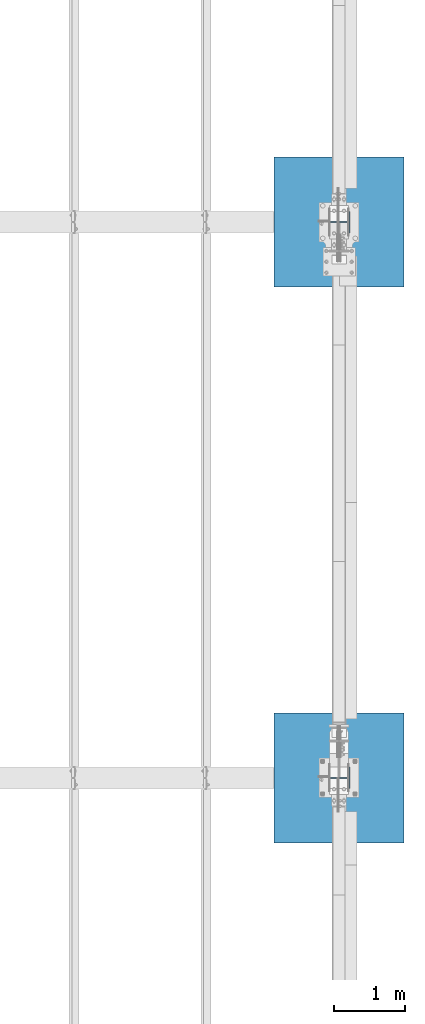
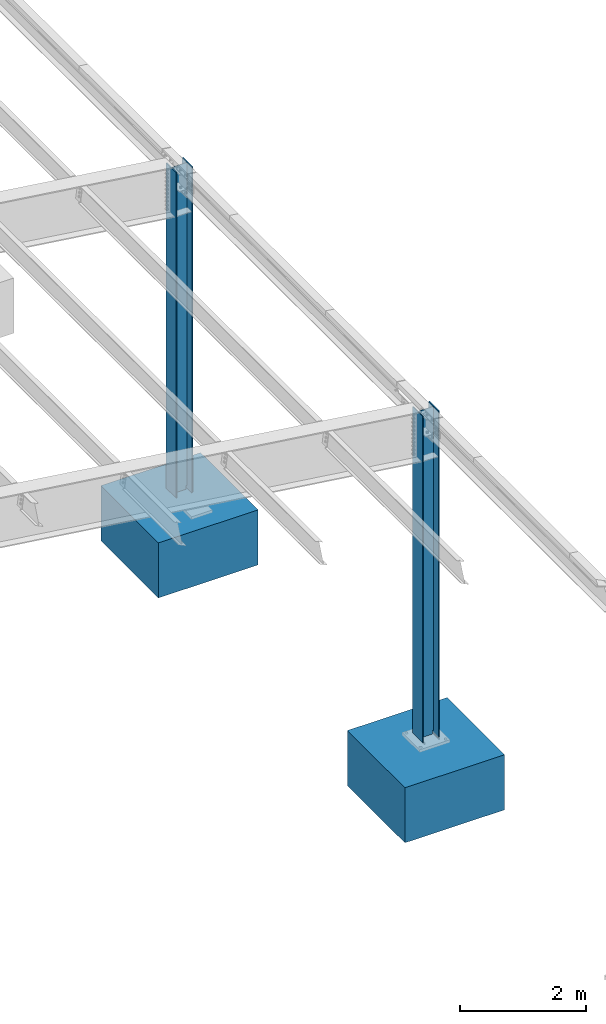
# One storey, part 361 of 1179: 4 columns, 4 elements without a shape of their own.
"""IFC2X3 building model written with IfcOpenShell, lengths in millimetres."""

from ifc_helpers import new_model, si_unit, frame, origin_with_axes, place, context, subcontext, project, spatial, faceted_brep, material, type_object, element, aggregate, save


model = new_model("IFC2X3")

# Units and contexts
model_context = context("Model", 3, precision=1e-05, world=origin_with_axes())
body_context = subcontext(model_context, "Body", "Model", "MODEL_VIEW")
ifc_project = project(units=[si_unit("LENGTHUNIT", "METRE", prefix="MILLI"), si_unit("AREAUNIT", "SQUARE_METRE"), si_unit("VOLUMEUNIT", "CUBIC_METRE"), si_unit("MASSUNIT", "GRAM", prefix="KILO"), si_unit("TIMEUNIT", "SECOND"), si_unit("PLANEANGLEUNIT", "RADIAN"), si_unit("SOLIDANGLEUNIT", "STERADIAN"), si_unit("THERMODYNAMICTEMPERATUREUNIT", "DEGREE_CELSIUS"), si_unit("LUMINOUSINTENSITYUNIT", "LUMEN")], contexts=[model_context])

# Site, building, storey
site_placement = place(None, origin_with_axes())
site = spatial("IfcSite", under=ifc_project, at=site_placement, CompositionType="ELEMENT")
building_placement = place(site_placement, origin_with_axes())
building = spatial("IfcBuilding", under=site, at=building_placement, Name="Undefined", CompositionType="ELEMENT")
storey_placement = place(building_placement, origin_with_axes())
storey = spatial("IfcBuildingStorey", under=building, at=storey_placement, Name="Undefined", CompositionType="ELEMENT", Elevation=0.0)

# Assembly, column
assembly_1_placement = place(storey_placement, origin_with_axes())
assembly_1 = element("IfcElementAssembly", 1, at=assembly_1_placement, inside=storey, Name="FOOTING", AssemblyPlace="NOTDEFINED", PredefinedType="REINFORCEMENT_UNIT")
ifc_material_1 = material(Name="CONCRETE/3000")
column_type_1 = type_object("IfcColumnType", PredefinedType="NOTDEFINED")
column_1_placement = place(assembly_1_placement, frame((38074.6, 19227.8, -1422.4), z_axis=(-1.0, 0.0, 0.0), x_axis=(0.0, 0.0, 1.0)))
column_1 = element("IfcColumn", 2, at=column_1_placement, type_object=column_type_1, material=ifc_material_1, Name="FOOTING", context=body_context, shape_type="Brep", body=[
    faceted_brep([(0.0, 914.400000000001, -914.400000000001), (0.0, 914.400000000001, 914.400000000001), (1066.8, 914.400000000001, 914.400000000001), (1066.8, 914.400000000001, -914.400000000001), (0.0, -914.400000000001, 914.400000000001), (1066.8, -914.400000000001, 914.400000000001), (0.0, -914.400000000001, -914.400000000001), (1066.8, -914.400000000001, -914.400000000001)], [[[0, 1, 2, 3]], [[1, 4, 5, 2]], [[4, 6, 7, 5]], [[6, 0, 3, 7]], [[5, 7, 3, 2]], [[6, 4, 1, 0]]]),
])
aggregate(assembly_1, [column_1])

assembly_2_placement = place(storey_placement, origin_with_axes())
assembly_2 = element("IfcElementAssembly", 3, at=assembly_2_placement, inside=storey, Name="FOOTING", AssemblyPlace="NOTDEFINED", PredefinedType="REINFORCEMENT_UNIT")
column_2_placement = place(assembly_2_placement, frame((38074.6, 27051.0, -1422.4), z_axis=(-1.0, 0.0, 0.0), x_axis=(0.0, 0.0, 1.0)))
column_2 = element("IfcColumn", 4, at=column_2_placement, type_object=column_type_1, material=ifc_material_1, Name="FOOTING", context=body_context, shape_type="Brep", body=[
    faceted_brep([(0.0, 914.400000000001, -914.400000000001), (0.0, 914.400000000001, 914.400000000001), (1066.8, 914.400000000001, 914.400000000001), (1066.8, 914.400000000001, -914.400000000001), (0.0, -914.400000000001, 914.400000000001), (1066.8, -914.400000000001, 914.400000000001), (0.0, -914.400000000001, -914.400000000001), (1066.8, -914.400000000001, -914.400000000001)], [[[0, 1, 2, 3]], [[1, 4, 5, 2]], [[4, 6, 7, 5]], [[6, 0, 3, 7]], [[5, 7, 3, 2]], [[6, 4, 1, 0]]]),
])
aggregate(assembly_2, [column_2])

assembly_3_placement = place(storey_placement, origin_with_axes())
assembly_3 = element("IfcElementAssembly", 5, at=assembly_3_placement, inside=storey, Name="COLUMN", AssemblyPlace="NOTDEFINED", PredefinedType="RIGID_FRAME")
ifc_material_2 = material(Name="STEEL/A992")
column_type_2 = type_object("IfcColumnType", Name="W12X72", PredefinedType="NOTDEFINED")
column_3_placement = place(assembly_3_placement, frame((38074.6, 19227.8, -355.6), z_axis=(-1.0, 0.0, 0.0), x_axis=(0.0, 0.0, 1.0)))
column_3 = element("IfcColumn", 6, at=column_3_placement, type_object=column_type_2, material=ifc_material_2, Name="COLUMN", ObjectType="W12X72", context=body_context, shape_type="Brep", body=[
    faceted_brep([(146.606600357246, -152.400000000001, 155.574999999997), (146.606600357246, 152.400000000001, 155.574999999997), (136.524983529018, 152.400000000001, 138.112500000003), (136.524983529014, 5.55625019064973, 138.112499999996), (136.29578370764, 5.5562501866807, 137.715499999998), (136.29578370764, -5.55625000000146, 137.715499999998), (136.524983529018, -5.55625000000146, 138.112500000003), (136.524983529018, -152.400000000001, 138.112500000003), (6470.65, 152.400000000001, -155.574999999997), (6470.65, -152.400000000001, -155.574999999997), (146.606617700325, -152.400000000001, -155.574999999997), (146.606617700325, 152.400000000001, -155.574999999997), (6470.65, -152.400000000001, -138.112500000003), (136.525382299677, -152.400000000001, -138.112500000003), (6470.65, -5.55625000000146, -138.112500000003), (136.525382299677, -5.55625000000146, -138.112500000003), (174.625000000001, -5.55625000000146, 137.715499999998), (174.625000000001, 5.55625013626559, 137.715499999998), (194.202660582074, 5.55625013373719, 131.287141068809), (194.202660582074, -5.55625000000146, 131.287141068809), (198.585373738856, 5.55625013263489, 128.290736246861), (198.585373738856, -5.55625000000146, 128.290736246861), (200.683292158598, 5.55625013091776, 123.41371309993), (200.683292158598, -5.55625000000146, 123.41371309993), (199.844634973188, 5.5562501291206, 118.171264187738), (199.844634973188, -5.55625000000146, 118.171264187738), (196.329956026479, 5.55625012780001, 114.192112472469), (196.329956026479, -5.55625000000146, 114.192112472469), (191.231195059057, 5.55625012737073, 112.712500000001), (191.231195059057, -5.55625000000146, 112.712500000001), (133.415804862977, 5.55625017320563, 112.712500000001), (127.000000000001, -5.55625000000146, 112.712500000001), (133.415804862977, 5.55625001754015, -112.712500000001), (127.000000000001, -5.55625000000146, -112.712500000001), (191.231195059057, 5.55625005558613, -112.712500000001), (191.231195059057, -5.55625000000146, -112.712500000001), (196.32995602648, 5.55625005499678, -114.192112472469), (196.32995602648, -5.55625000000146, -114.192112472469), (199.844634973189, 5.55625005357069, -118.171264187738), (199.844634973189, -5.55625000000146, -118.171264187738), (200.683292158599, 5.55625005174807, -123.41371309993), (200.683292158599, -5.55625000000146, -123.41371309993), (198.585373738856, 5.55625005009642, -128.290736246861), (198.585373738856, -5.55625000000146, -128.290736246861), (194.202660582074, 5.55625004912872, -131.287141068809), (194.202660582074, -5.55625000000146, -131.287141068809), (174.625000000001, 5.55625004720423, -137.715499999998), (174.625000000001, -5.55625000000146, -137.715499999998), (136.296191149838, 5.55625000355576, -137.715499999998), (136.296191149838, -5.55625000000146, -137.715499999998), (6470.65, 5.55625000000146, -138.112500000003), (6470.65, 152.400000000001, -138.112500000003), (136.525382299677, 152.400000000001, -138.112500000003), (136.525382299677, 5.55625000000146, -138.112500000003), (6470.65, 5.55625000000146, 138.112500000003), (6470.65, 152.400000000001, 138.112500000003), (6470.65, 152.400000000001, 155.574999999997), (6470.65, -152.400000000001, 155.574999999997), (6470.65, -152.400000000001, 138.112500000003), (6470.65, -5.55625000000146, 138.112500000003)], [[[0, 1, 2, 3, 4, 5, 6, 7]], [[8, 9, 10, 11]], [[9, 12, 13, 10]], [[12, 14, 15, 13]], [[16, 17, 18, 19]], [[19, 18, 20, 21]], [[21, 20, 22, 23]], [[23, 22, 24, 25]], [[25, 24, 26, 27]], [[27, 26, 28, 29]], [[29, 28, 30, 31]], [[32, 33, 31, 30]], [[33, 32, 34, 35]], [[35, 34, 36, 37]], [[37, 36, 38, 39]], [[39, 38, 40, 41]], [[41, 40, 42, 43]], [[43, 42, 44, 45]], [[45, 44, 46, 47]], [[47, 46, 48, 49]], [[50, 51, 52, 53]], [[10, 13, 15, 49, 48, 53, 52, 11]], [[51, 8, 11, 52]], [[50, 54, 55, 56, 57, 58, 59, 14, 12, 9, 8, 51]], [[58, 57, 0, 7]], [[59, 58, 7, 6]], [[16, 19, 21, 23, 25, 27, 29, 31, 33, 35, 37, 39, 41, 43, 45, 47, 49, 15, 14, 59, 6, 5]], [[17, 16, 5, 4]], [[54, 50, 53, 48, 46, 44, 42, 40, 38, 36, 34, 32, 30, 28, 26, 24, 22, 20, 18, 17, 4, 3]], [[55, 54, 3, 2]], [[56, 55, 2, 1]], [[57, 56, 1, 0]]]),
])
aggregate(assembly_3, [column_3])

assembly_4_placement = place(storey_placement, origin_with_axes())
assembly_4 = element("IfcElementAssembly", 7, at=assembly_4_placement, inside=storey, Name="COLUMN", AssemblyPlace="NOTDEFINED", PredefinedType="RIGID_FRAME")
column_4_placement = place(assembly_4_placement, frame((38074.6, 27051.0, -355.6), z_axis=(-1.0, 0.0, 0.0), x_axis=(0.0, 0.0, 1.0)))
column_4 = element("IfcColumn", 8, at=column_4_placement, type_object=column_type_2, material=ifc_material_2, Name="COLUMN", ObjectType="W12X72", context=body_context, shape_type="Brep", body=[
    faceted_brep([(146.606600357246, -152.400000000001, 155.574999999997), (146.606600357246, 152.400000000001, 155.574999999997), (136.524983529018, 152.400000000001, 138.112500000003), (136.524983529014, 5.5923119575782, 138.112499999996), (136.29578370764, 5.59156128883114, 137.715499999998), (136.29578370764, -5.55625000000146, 137.715499999998), (136.524983529018, -5.55625000000146, 138.112500000003), (136.524983529018, -152.400000000001, 138.112500000003), (6451.6, 152.400000000001, -155.574999999997), (6451.6, -152.400000000001, -155.574999999997), (146.606617700325, -152.400000000001, -155.574999999997), (146.606617700325, 152.400000000001, -155.574999999997), (6451.6, -152.400000000001, -138.112500000003), (136.525382299677, -152.400000000001, -138.112500000003), (6451.6, -5.55625000000146, -138.112500000003), (136.525382299677, -5.55625000000146, -138.112500000003), (174.625000000001, -5.55625000000146, 137.715499999998), (174.625000000001, 5.58202458263622, 137.715499999998), (194.202660582074, 5.58154646018011, 131.287141068809), (194.202660582074, -5.55625000000146, 131.287141068809), (198.585373738856, 5.58133769453707, 128.290736246861), (198.585373738856, -5.55625000000146, 128.290736246861), (200.683292158598, 5.58101287031604, 123.41371309993), (200.683292158598, -5.55625000000146, 123.41371309993), (199.844634973188, 5.58067290383769, 118.171264187738), (199.844634973188, -5.55625000000146, 118.171264187738), (196.329956026479, 5.58042341581677, 114.192112472469), (196.329956026479, -5.55625000000146, 114.192112472469), (191.231195059057, 5.5803419171425, 112.712500000001), (191.231195059057, -5.55625000000146, 112.712500000001), (133.415804861789, 5.58901203770074, 112.712500000001), (127.000000000001, -5.55625000000146, 112.712500000001), (133.415804861789, 5.55956767470343, -112.712500000001), (127.000000000001, -5.55625000000146, -112.712500000001), (191.231195059057, 5.56676368933404, -112.712500000001), (191.231195059057, -5.55625000000146, -112.712500000001), (196.32995602648, 5.56665249985235, -114.192112472469), (196.32995602648, -5.55625000000146, -114.192112472469), (199.844634973189, 5.56638259198735, -118.171264187738), (199.844634973189, -5.55625000000146, -118.171264187738), (200.683292158599, 5.56603782065577, -123.41371309993), (200.683292158599, -5.55625000000146, -123.41371309993), (198.585373738856, 5.56572529934419, -128.290736246861), (198.585373738856, -5.55625000000146, -128.290736246861), (194.202660582074, 5.56554212211631, -131.287141068809), (194.202660582074, -5.55625000000146, -131.287141068809), (174.625000000001, 5.56517819395231, -137.715499999998), (174.625000000001, -5.55625000000146, -137.715499999998), (136.296191149838, 5.55692228169573, -137.715499999998), (136.296191149838, -5.55625000000146, -137.715499999998), (6451.6, 5.55625000000146, -138.112500000003), (6451.6, 152.400000000001, -138.112500000003), (136.525382299677, 152.400000000001, -138.112500000003), (136.525382299677, 5.55625000000146, -138.112500000003), (6451.6, 5.55625000000146, 138.112500000003), (6451.6, 152.400000000001, 138.112500000003), (6451.6, 152.400000000001, 155.574999999997), (6451.6, -152.400000000001, 155.574999999997), (6451.6, -152.400000000001, 138.112500000003), (6451.6, -5.55625000000146, 138.112500000003)], [[[0, 1, 2, 3, 4, 5, 6, 7]], [[8, 9, 10, 11]], [[9, 12, 13, 10]], [[12, 14, 15, 13]], [[16, 17, 18, 19]], [[19, 18, 20, 21]], [[21, 20, 22, 23]], [[23, 22, 24, 25]], [[25, 24, 26, 27]], [[27, 26, 28, 29]], [[29, 28, 30, 31]], [[32, 33, 31, 30]], [[33, 32, 34, 35]], [[35, 34, 36, 37]], [[37, 36, 38, 39]], [[39, 38, 40, 41]], [[41, 40, 42, 43]], [[43, 42, 44, 45]], [[45, 44, 46, 47]], [[47, 46, 48, 49]], [[50, 51, 52, 53]], [[10, 13, 15, 49, 48, 53, 52, 11]], [[51, 8, 11, 52]], [[50, 54, 55, 56, 57, 58, 59, 14, 12, 9, 8, 51]], [[58, 57, 0, 7]], [[59, 58, 7, 6]], [[16, 19, 21, 23, 25, 27, 29, 31, 33, 35, 37, 39, 41, 43, 45, 47, 49, 15, 14, 59, 6, 5]], [[17, 16, 5, 4]], [[54, 50, 53, 48, 46, 44, 42, 40, 38, 36, 34, 32, 30, 28, 26, 24, 22, 20, 18, 17, 4, 3]], [[55, 54, 3, 2]], [[56, 55, 2, 1]], [[57, 56, 1, 0]]]),
])
aggregate(assembly_4, [column_4])

save(model, "model.ifc")
